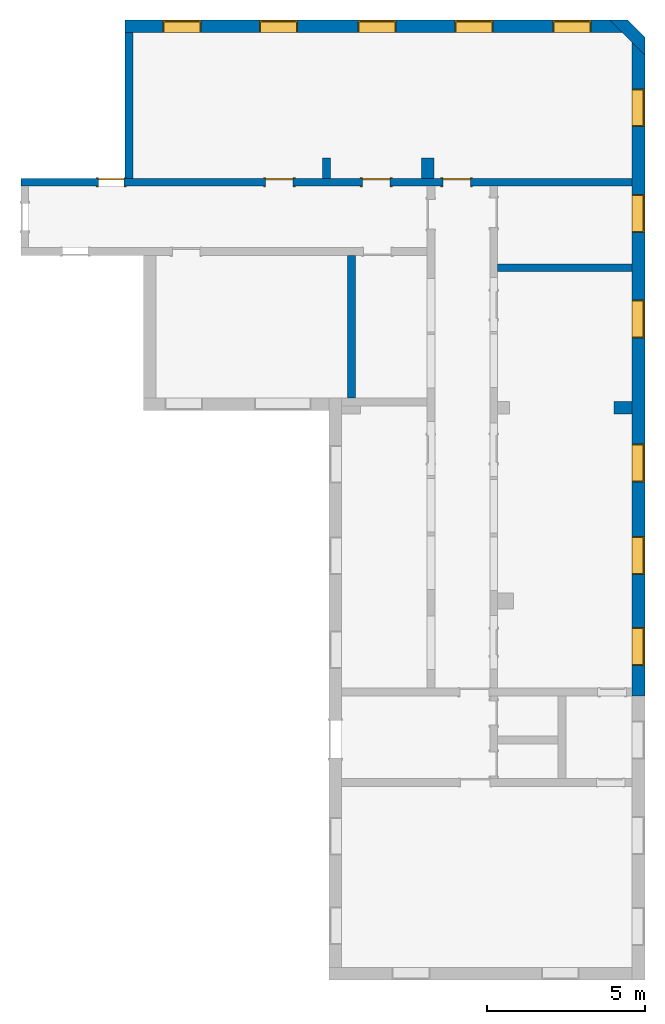
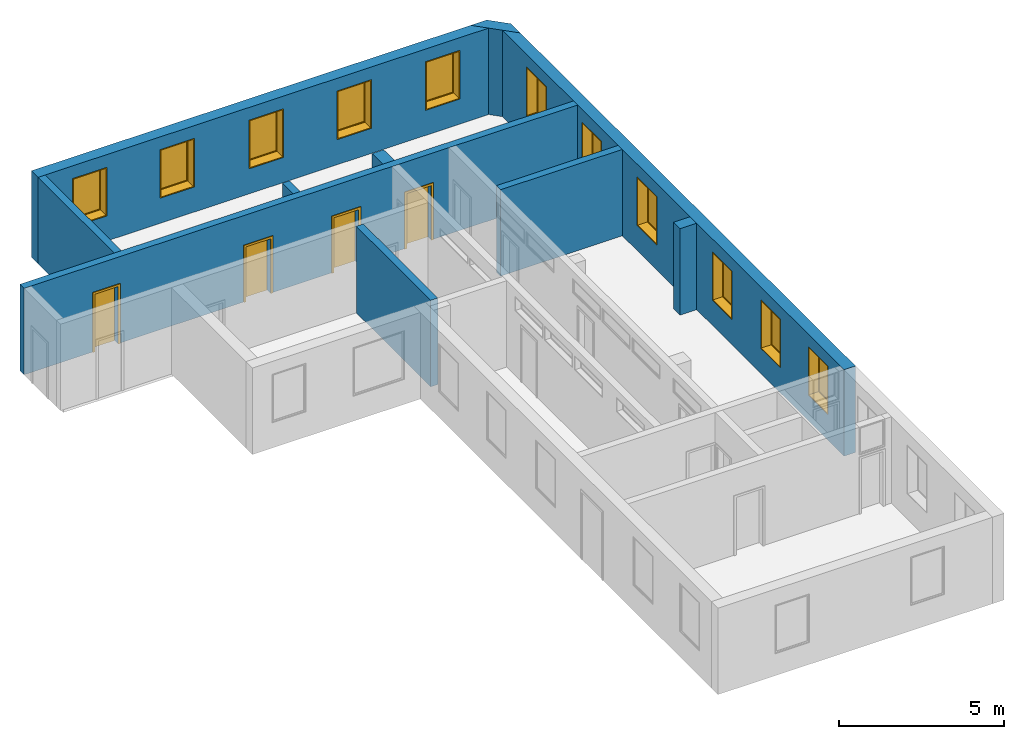
"""IFC2X3 building model written with IfcOpenShell, lengths in millimetres."""

from ifc_helpers import new_model, entity, si_unit, converted_unit, derived_unit, direction, frame, frame_2d, origin, origin_2d_with_axis, place, context, subcontext, project, spatial, polyline, rectangle, outline, extrude, source, transform, mapped, material, material_list, layer, layer_set, layer_usage, type_object, type_shapes, element, fill, save


model = new_model("IFC2X3")

# Units and contexts
model_context = context("Model", 3, precision=0.01, world=origin(), true_north=direction((6.12303176911189e-17, 1.0)))
context_of_model = context(None, 3, precision=0.01, world=origin(), true_north=direction((6.12303176911189e-17, 1.0)))
body_context = subcontext(model_context, "Body", "Model", "MODEL_VIEW")
ifc_project = project(units=[si_unit("LENGTHUNIT", "METRE", prefix="MILLI"), si_unit("AREAUNIT", "SQUARE_METRE"), si_unit("VOLUMEUNIT", "CUBIC_METRE"), converted_unit("PLANEANGLEUNIT", "DEGREE", entity("IfcRatioMeasure", 0.0174532925199433), si_unit("PLANEANGLEUNIT", "RADIAN"), dimensions=[0, 0, 0, 0, 0, 0, 0]), si_unit("MASSUNIT", "GRAM", prefix="KILO"), si_unit("TIMEUNIT", "SECOND"), si_unit("FREQUENCYUNIT", "HERTZ"), si_unit("THERMODYNAMICTEMPERATUREUNIT", "DEGREE_CELSIUS"), derived_unit("THERMALTRANSMITTANCEUNIT", [(si_unit("MASSUNIT", "GRAM", prefix="KILO"), 1), (si_unit("THERMODYNAMICTEMPERATUREUNIT", "KELVIN"), -1), (si_unit("TIMEUNIT", "SECOND"), -3)]), derived_unit("VOLUMETRICFLOWRATEUNIT", [(si_unit("LENGTHUNIT", "METRE"), 3), (si_unit("TIMEUNIT", "SECOND"), -1)]), si_unit("ELECTRICCURRENTUNIT", "AMPERE"), si_unit("ELECTRICVOLTAGEUNIT", "VOLT"), si_unit("POWERUNIT", "WATT"), si_unit("FORCEUNIT", "NEWTON", prefix="KILO"), si_unit("ILLUMINANCEUNIT", "LUX"), si_unit("LUMINOUSFLUXUNIT", "LUMEN"), si_unit("LUMINOUSINTENSITYUNIT", "CANDELA"), si_unit("PRESSUREUNIT", "PASCAL")], contexts=[model_context, context_of_model])

# Site, building, storey
site_placement = place(None, origin())
site = spatial("IfcSite", under=ifc_project, at=site_placement, CompositionType="ELEMENT")
building_placement = place(site_placement, origin())
building = spatial("IfcBuilding", under=site, at=building_placement, CompositionType="ELEMENT")
storey_1_placement = place(building_placement, origin())
storey_1 = spatial("IfcBuildingStorey", under=building, at=storey_1_placement, Name="i Plan", CompositionType="ELEMENT", Elevation=-5.41433564649196e-13)

# Wall, openings
ifc_material_1 = material(Name="Brick, Common")
ifc_layer_1 = layer(ifc_material_1, 400.0)
ifc_layer_set_1 = layer_set([ifc_layer_1], Name="Basic Wall:400mm")
ifc_layer_usage_1 = layer_usage(ifc_layer_set_1, "AXIS2", "NEGATIVE", 200.0)
wall_type_1 = type_object("IfcWallType", Name="Basic Wall:400mm", PredefinedType="STANDARD", material=ifc_layer_set_1)
wall_1_placement = place(storey_1_placement, frame((-10978.4537950618, 14416.3951971478, 0.0)))
wall_1 = element("IfcWallStandardCase", 1, at=wall_1_placement, inside=storey_1, type_object=wall_type_1, material=ifc_layer_usage_1, Name="Basic Wall:400mm", ObjectType="Basic Wall:400mm", context=body_context, shape_type="SweptSolid", body=[
    extrude(outline(polyline([(15778.1296869568, -200.0), (15378.1296869568, 200.0), (0.0, 200.0), (0.0, -200.0), (250.0, -200.0), (15778.1296869568, -200.0)])), origin(), (0.0, 0.0, 1.0), 3199.99999999984),
])
opening_1_placement = place(wall_1_placement, frame((7390.0, -200.0, 930.0)))
opening_1 = element("IfcOpeningElement", 2, at=opening_1_placement, cuts=wall_1, Name="M_Fixed:72_1", ObjectType="Opening", context=body_context, shape_type="SweptSolid", body=[
    extrude(rectangle(XDim=1800.0, YDim=1200.0, at=frame_2d((899.999999999998, 600.0), x_axis=(1.0, 0.0))), frame((0.0, 0.0, 0.0), z_axis=(0.0, 1.0, 0.0), x_axis=(0.0, 0.0, 1.0)), (0.0, 0.0, 1.0), 400.0),
])
opening_2_placement = place(wall_1_placement, frame((10470.0, -200.0, 930.0)))
opening_2 = element("IfcOpeningElement", 3, at=opening_2_placement, cuts=wall_1, Name="M_Fixed:72_1", ObjectType="Opening", context=body_context, shape_type="SweptSolid", body=[
    extrude(rectangle(XDim=1800.0, YDim=1200.0, at=frame_2d((899.999999999998, 600.0), x_axis=(1.0, 0.0))), frame((0.0, 0.0, 0.0), z_axis=(0.0, 1.0, 0.0), x_axis=(0.0, 0.0, 1.0)), (0.0, 0.0, 1.0), 400.0),
])
opening_3_placement = place(wall_1_placement, frame((13570.0, -200.0, 930.0)))
opening_3 = element("IfcOpeningElement", 4, at=opening_3_placement, cuts=wall_1, Name="M_Fixed:72_1", ObjectType="Opening", context=body_context, shape_type="SweptSolid", body=[
    extrude(rectangle(XDim=1800.0, YDim=1200.0, at=frame_2d((899.999999999998, 600.0), x_axis=(1.0, 0.0))), frame((0.0, 0.0, 0.0), z_axis=(0.0, 1.0, 0.0), x_axis=(0.0, 0.0, 1.0)), (0.0, 0.0, 1.0), 400.0),
])
opening_4_placement = place(wall_1_placement, frame((4270.0, -200.0, 930.0)))
opening_4 = element("IfcOpeningElement", 5, at=opening_4_placement, cuts=wall_1, Name="M_Fixed:72_1", ObjectType="Opening", context=body_context, shape_type="SweptSolid", body=[
    extrude(rectangle(XDim=1800.0, YDim=1200.0, at=frame_2d((899.999999999998, 600.0), x_axis=(1.0, 0.0))), frame((0.0, 0.0, 0.0), z_axis=(0.0, 1.0, 0.0), x_axis=(0.0, 0.0, 1.0)), (0.0, 0.0, 1.0), 400.0),
])
opening_5_placement = place(wall_1_placement, frame((1210.0, -200.0, 930.0)))
opening_5 = element("IfcOpeningElement", 6, at=opening_5_placement, cuts=wall_1, Name="M_Fixed:72_1", ObjectType="Opening", context=body_context, shape_type="SweptSolid", body=[
    extrude(rectangle(XDim=1800.0, YDim=1200.0, at=frame_2d((899.999999999998, 600.0), x_axis=(1.0, 0.0))), frame((0.0, 0.0, 0.0), z_axis=(0.0, 1.0, 0.0), x_axis=(0.0, 0.0, 1.0)), (0.0, 0.0, 1.0), 400.0),
])

# Storey
storey_2_placement = place(building_placement, frame((0.0, 0.0, 960.0)))
storey_2 = spatial("IfcBuildingStorey", under=building, at=storey_2_placement, Name="Bottom windows", CompositionType="ELEMENT", Elevation=959.999999999999)

# Window
ifc_material_2 = material(Name="Glass")
ifc_material_3 = material(Name="Sash")
ifc_material_list_1 = material_list([ifc_material_2, ifc_material_3])
ifc_material_list_2 = material_list([ifc_material_2, ifc_material_3])
window_style = type_object("IfcWindowStyle", Name="72", ConstructionType="NOTDEFINED", OperationType="NOTDEFINED", ParameterTakesPrecedence=False, Sizeable=False, material=ifc_material_list_2)
shared_shape_1 = source(origin(), body_context, "Body", "SweptSolid", [
    extrude(rectangle(XDim=12.0, YDim=1074.0, at=origin_2d_with_axis()), frame((600.0, 359.0, 63.0), z_axis=(0.0, 0.0, 1.0), x_axis=(0.0, -1.0, 0.0)), (0.0, 0.0, 1.0), 1674.0),
    extrude(outline(polyline([(-581.0, -881.0), (581.0, -881.0), (581.0, 881.0), (-581.0, 881.0), (-581.0, -881.0)]), holes=[polyline([(-537.0, -837.0), (-537.0, 837.0), (537.0, 837.0), (537.0, -837.0), (-537.0, -837.0)])]), frame((600.0, 337.0, 900.0), z_axis=(0.0, 1.0, 0.0), x_axis=(1.0, 0.0, 0.0)), (0.0, 0.0, 1.0), 44.0000000000274),
    extrude(outline(polyline([(-600.0, -900.0), (600.0, -900.0), (600.0, 900.0), (-600.0, 900.0), (-600.0, -900.0)]), holes=[polyline([(-581.0, -881.0), (-581.0, 881.0), (581.0, 881.0), (581.0, -881.0), (-581.0, -881.0)])]), frame((600.0, 337.0, 900.0), z_axis=(0.0, 1.0, 0.0), x_axis=(1.0, 0.0, 0.0)), (0.0, 0.0, 1.0), 63.0000000000275),
    extrude(outline(polyline([(-600.0, -900.0), (600.0, -900.0), (600.0, 900.0), (-600.0, 900.0), (-600.0, -900.0)]), holes=[polyline([(-568.0, -868.0), (-568.0, 868.0), (568.0, 868.0), (568.0, -868.0), (-568.0, -868.0)])]), frame((600.0, 0.0, 900.0), z_axis=(0.0, 1.0, 0.0), x_axis=(1.0, 0.0, 0.0)), (0.0, 0.0, 1.0), 336.999999999973),
])
type_shapes(window_style, [shared_shape_1])
window_1_placement = place(opening_1_placement, origin())
window_1 = element("IfcWindow", 7, at=window_1_placement, inside=storey_2, type_object=window_style, material=ifc_material_list_1, Name="M_Fixed:72", ObjectType="72", OverallHeight=1800.0, OverallWidth=1200.0, context=body_context, shape_type="MappedRepresentation", body=[
    mapped(shared_shape_1, transform((0.0, 0.0, 0.0), scale=1.0)),
])

fill(opening_1, window_1)

ifc_material_list_3 = material_list([ifc_material_2, ifc_material_3])
window_2_placement = place(opening_2_placement, origin())
window_2 = element("IfcWindow", 8, at=window_2_placement, inside=storey_2, type_object=window_style, material=ifc_material_list_3, Name="M_Fixed:72", ObjectType="72", OverallHeight=1800.0, OverallWidth=1200.0, context=body_context, shape_type="MappedRepresentation", body=[
    mapped(shared_shape_1, transform((0.0, 0.0, 0.0), scale=1.0)),
])

fill(opening_2, window_2)

ifc_material_list_4 = material_list([ifc_material_2, ifc_material_3])
window_3_placement = place(opening_3_placement, origin())
window_3 = element("IfcWindow", 9, at=window_3_placement, inside=storey_2, type_object=window_style, material=ifc_material_list_4, Name="M_Fixed:72", ObjectType="72", OverallHeight=1800.0, OverallWidth=1200.0, context=body_context, shape_type="MappedRepresentation", body=[
    mapped(shared_shape_1, transform((0.0, 0.0, 0.0), scale=1.0)),
])

fill(opening_3, window_3)

ifc_material_list_5 = material_list([ifc_material_2, ifc_material_3])
window_4_placement = place(opening_4_placement, origin())
window_4 = element("IfcWindow", 10, at=window_4_placement, inside=storey_2, type_object=window_style, material=ifc_material_list_5, Name="M_Fixed:72", ObjectType="72", OverallHeight=1800.0, OverallWidth=1200.0, context=body_context, shape_type="MappedRepresentation", body=[
    mapped(shared_shape_1, transform((0.0, 0.0, 0.0), scale=1.0)),
])

fill(opening_4, window_4)

ifc_material_list_6 = material_list([ifc_material_2, ifc_material_3])
window_5_placement = place(opening_5_placement, origin())
window_5 = element("IfcWindow", 11, at=window_5_placement, inside=storey_2, type_object=window_style, material=ifc_material_list_6, Name="M_Fixed:72", ObjectType="72", OverallHeight=1800.0, OverallWidth=1200.0, context=body_context, shape_type="MappedRepresentation", body=[
    mapped(shared_shape_1, transform((0.0, 0.0, 0.0), scale=1.0)),
])

fill(opening_5, window_5)

# Wall
ifc_layer_usage_2 = layer_usage(ifc_layer_set_1, "AXIS2", "NEGATIVE", 200.0)
wall_2_placement = place(storey_1_placement, frame((4541.09724813232, 14757.8165533851, 0.0), z_axis=(0.0, 0.0, 1.0), x_axis=(0.707106781186546, -0.707106781186549, 0.0)))
element("IfcWallStandardCase", 12, at=wall_2_placement, inside=storey_1, type_object=wall_type_1, material=ifc_layer_usage_2, Name="Basic Wall:400mm", ObjectType="Basic Wall:400mm", context=body_context, shape_type="SweptSolid", body=[
    extrude(outline(polyline([(1558.97832483456, -200.0), (1158.97832483456, 200.0), (400.0, 200.0), (0.0, -200.0), (565.685424949238, -200.0), (993.292899885323, -200.0), (1558.97832483456, -200.0)])), origin(), (0.0, 0.0, 1.0), 3199.99999999984),
])

# Wall, openings, windows
ifc_layer_usage_3 = layer_usage(ifc_layer_set_1, "AXIS2", "NEGATIVE", 200.0)
wall_3_placement = place(storey_1_placement, frame((5302.04003710837, 13914.0310519344, 0.0), z_axis=(0.0, 0.0, 1.0), x_axis=(0.0, -1.0, 0.0)))
wall_3 = element("IfcWallStandardCase", 13, at=wall_3_placement, inside=storey_1, type_object=wall_type_1, material=ifc_layer_usage_3, Name="Basic Wall:400mm", ObjectType="Basic Wall:400mm", context=body_context, shape_type="SweptSolid", body=[
    extrude(outline(polyline([(20727.1273479506, -200.0), (20727.1273479506, 200.0), (400.0, 200.0), (0.0, -200.0), (4317.22230867366, -200.0), (4567.22230867366, -200.0), (7027.22230867366, -200.0), (7277.22230867366, -200.0), (11383.6923277793, -200.0), (11783.6923277793, -200.0), (20477.1273479506, -200.0), (20727.1273479506, -200.0)])), origin(), (0.0, 0.0, 1.0), 3199.99999999984),
])
opening_6_placement = place(wall_3_placement, frame((12737.2223086737, -200.0, 930.0)))
opening_6 = element("IfcOpeningElement", 14, at=opening_6_placement, cuts=wall_3, Name="M_Fixed:72_1", ObjectType="Opening", context=body_context, shape_type="SweptSolid", body=[
    extrude(rectangle(XDim=1800.0, YDim=1200.0, at=frame_2d((899.999999999998, 600.0), x_axis=(1.0, 0.0))), frame((0.0, 0.0, 0.0), z_axis=(0.0, 1.0, 0.0), x_axis=(0.0, 0.0, 1.0)), (0.0, 0.0, 1.0), 400.0),
])
opening_7_placement = place(wall_3_placement, frame((1477.22230867366, -200.0, 930.0)))
opening_7 = element("IfcOpeningElement", 15, at=opening_7_placement, cuts=wall_3, Name="M_Fixed:72_1", ObjectType="Opening", context=body_context, shape_type="SweptSolid", body=[
    extrude(rectangle(XDim=1800.0, YDim=1200.0, at=frame_2d((899.999999999998, 600.0), x_axis=(1.0, 0.0))), frame((0.0, 0.0, 0.0), z_axis=(0.0, 1.0, 0.0), x_axis=(0.0, 0.0, 1.0)), (0.0, 0.0, 1.0), 400.0),
])
opening_8_placement = place(wall_3_placement, frame((4827.22230867366, -200.0, 930.0)))
opening_8 = element("IfcOpeningElement", 16, at=opening_8_placement, cuts=wall_3, Name="M_Fixed:72_1", ObjectType="Opening", context=body_context, shape_type="SweptSolid", body=[
    extrude(rectangle(XDim=1800.0, YDim=1200.0, at=frame_2d((899.999999999998, 600.0), x_axis=(1.0, 0.0))), frame((0.0, 0.0, 0.0), z_axis=(0.0, 1.0, 0.0), x_axis=(0.0, 0.0, 1.0)), (0.0, 0.0, 1.0), 400.0),
])
opening_9_placement = place(wall_3_placement, frame((8177.22230867366, -200.0, 930.0)))
opening_9 = element("IfcOpeningElement", 17, at=opening_9_placement, cuts=wall_3, Name="M_Fixed:72_1", ObjectType="Opening", context=body_context, shape_type="SweptSolid", body=[
    extrude(rectangle(XDim=1800.0, YDim=1200.0, at=frame_2d((899.999999999998, 599.999999999999), x_axis=(1.0, 0.0))), frame((0.0, 0.0, 0.0), z_axis=(0.0, 1.0, 0.0), x_axis=(0.0, 0.0, 1.0)), (0.0, 0.0, 1.0), 400.0),
])
opening_10_placement = place(wall_3_placement, frame((15677.1273479506, -200.0, 930.0)))
opening_10 = element("IfcOpeningElement", 18, at=opening_10_placement, cuts=wall_3, Name="M_Fixed:72_1", ObjectType="Opening", context=body_context, shape_type="SweptSolid", body=[
    extrude(rectangle(XDim=1800.0, YDim=1200.0, at=frame_2d((899.999999999998, 600.0), x_axis=(1.0, 0.0))), frame((0.0, 0.0, 0.0), z_axis=(0.0, 1.0, 0.0), x_axis=(0.0, 0.0, 1.0)), (0.0, 0.0, 1.0), 400.0),
])
opening_11_placement = place(wall_3_placement, frame((18557.1273479506, -200.0, 946.352774904419)))
opening_11 = element("IfcOpeningElement", 19, at=opening_11_placement, cuts=wall_3, Name="M_Fixed:72_1", ObjectType="Opening", context=body_context, shape_type="SweptSolid", body=[
    extrude(rectangle(XDim=1800.0, YDim=1200.0, at=frame_2d((899.999999999998, 600.0), x_axis=(1.0, 0.0))), frame((0.0, 0.0, 0.0), z_axis=(0.0, 1.0, 0.0), x_axis=(0.0, 0.0, 1.0)), (0.0, 0.0, 1.0), 400.0),
])
ifc_material_list_7 = material_list([ifc_material_2, ifc_material_3])
window_6_placement = place(opening_7_placement, origin())
window_6 = element("IfcWindow", 20, at=window_6_placement, inside=storey_2, type_object=window_style, material=ifc_material_list_7, Name="M_Fixed:72", ObjectType="72", OverallHeight=1800.0, OverallWidth=1200.0, context=body_context, shape_type="MappedRepresentation", body=[
    mapped(shared_shape_1, transform((0.0, 0.0, 0.0), scale=1.0)),
])
fill(opening_7, window_6)
ifc_material_list_8 = material_list([ifc_material_2, ifc_material_3])
window_7_placement = place(opening_8_placement, origin())
window_7 = element("IfcWindow", 21, at=window_7_placement, inside=storey_2, type_object=window_style, material=ifc_material_list_8, Name="M_Fixed:72", ObjectType="72", OverallHeight=1800.0, OverallWidth=1200.0, context=body_context, shape_type="MappedRepresentation", body=[
    mapped(shared_shape_1, transform((0.0, 0.0, 0.0), scale=1.0)),
])
fill(opening_8, window_7)
ifc_material_list_9 = material_list([ifc_material_2, ifc_material_3])
window_8_placement = place(opening_9_placement, origin())
window_8 = element("IfcWindow", 22, at=window_8_placement, inside=storey_2, type_object=window_style, material=ifc_material_list_9, Name="M_Fixed:72", ObjectType="72", OverallHeight=1800.0, OverallWidth=1200.0, context=body_context, shape_type="MappedRepresentation", body=[
    mapped(shared_shape_1, transform((0.0, 0.0, 0.0), scale=1.0)),
])
fill(opening_9, window_8)
ifc_material_list_10 = material_list([ifc_material_2, ifc_material_3])
window_9_placement = place(opening_6_placement, origin())
window_9 = element("IfcWindow", 23, at=window_9_placement, inside=storey_2, type_object=window_style, material=ifc_material_list_10, Name="M_Fixed:72", ObjectType="72", OverallHeight=1800.0, OverallWidth=1200.0, context=body_context, shape_type="MappedRepresentation", body=[
    mapped(shared_shape_1, transform((0.0, 0.0, 0.0), scale=1.0)),
])
fill(opening_6, window_9)
ifc_material_list_11 = material_list([ifc_material_2, ifc_material_3])
window_10_placement = place(opening_10_placement, origin())
window_10 = element("IfcWindow", 24, at=window_10_placement, inside=storey_2, type_object=window_style, material=ifc_material_list_11, Name="M_Fixed:72", ObjectType="72", OverallHeight=1800.0, OverallWidth=1200.0, context=body_context, shape_type="MappedRepresentation", body=[
    mapped(shared_shape_1, transform((0.0, 0.0, 0.0), scale=1.0)),
])
fill(opening_10, window_10)
ifc_material_list_12 = material_list([ifc_material_2, ifc_material_3])
window_11_placement = place(opening_11_placement, origin())
window_11 = element("IfcWindow", 25, at=window_11_placement, inside=storey_1, type_object=window_style, material=ifc_material_list_12, Name="M_Fixed:72", ObjectType="72", OverallHeight=1800.0, OverallWidth=1200.0, context=body_context, shape_type="MappedRepresentation", body=[
    mapped(shared_shape_1, transform((0.0, 0.0, 0.0), scale=1.0)),
])
fill(opening_11, window_11)

# Wall, openings, doors
ifc_material_4 = material(Name="Default Wall")
ifc_layer_2 = layer(ifc_material_4, 250.0)
ifc_layer_set_2 = layer_set([ifc_layer_2], Name="Basic Wall:250 mm")
ifc_layer_usage_4 = layer_usage(ifc_layer_set_2, "AXIS2", "NEGATIVE", 125.0)
wall_type_2 = type_object("IfcWallType", Name="Basic Wall:250 mm", PredefinedType="STANDARD", material=ifc_layer_set_2)
wall_4_placement = place(storey_1_placement, frame((-14277.9599628916, 9471.8087432608, 0.0)))
wall_4 = element("IfcWallStandardCase", 26, at=wall_4_placement, inside=storey_1, type_object=wall_type_2, material=ifc_layer_usage_4, Name="Basic Wall:250 mm", ObjectType="Basic Wall:250 mm", context=body_context, shape_type="SweptSolid", body=[
    extrude(rectangle(XDim=19380.0, YDim=249.999999999999, at=frame_2d((9690.0, 5.6843418860808e-14), x_axis=(-1.0, 0.0))), origin(), (0.0, 0.0, 1.0), 3199.99999999984),
])
opening_12_placement = place(wall_4_placement, frame((13386.3718701131, -125.0, 0.0)))
opening_12 = element("IfcOpeningElement", 27, at=opening_12_placement, cuts=wall_4, Name="M_Single-Flush:0864 x 2032mm:1", ObjectType="Opening", context=body_context, shape_type="SweptSolid", body=[
    extrude(rectangle(XDim=863.999999999999, YDim=2032.0, at=frame_2d((1016.0, 432.0), x_axis=(0.0, 1.0))), frame((0.0, 0.0, 0.0), z_axis=(0.0, 1.0, 0.0), x_axis=(0.0, 0.0, 1.0)), (0.0, 0.0, 1.0), 250.0),
])
opening_13_placement = place(wall_4_placement, frame((10836.3718701131, -125.0, 0.0)))
opening_13 = element("IfcOpeningElement", 28, at=opening_13_placement, cuts=wall_4, Name="M_Single-Flush:0864 x 2032mm:1", ObjectType="Opening", context=body_context, shape_type="SweptSolid", body=[
    extrude(rectangle(XDim=863.999999999999, YDim=2032.0, at=frame_2d((1016.0, 432.0), x_axis=(0.0, 1.0))), frame((0.0, 0.0, 0.0), z_axis=(0.0, 1.0, 0.0), x_axis=(0.0, 0.0, 1.0)), (0.0, 0.0, 1.0), 250.0),
])
opening_14_placement = place(wall_4_placement, frame((7762.37187011309, -125.0, 0.0)))
opening_14 = element("IfcOpeningElement", 29, at=opening_14_placement, cuts=wall_4, Name="M_Single-Flush:0864 x 2032mm:1", ObjectType="Opening", context=body_context, shape_type="SweptSolid", body=[
    extrude(rectangle(XDim=863.999999999999, YDim=2032.0, at=frame_2d((1016.0, 432.0), x_axis=(0.0, -1.0))), frame((0.0, 0.0, 0.0), z_axis=(0.0, 1.0, 0.0), x_axis=(0.0, 0.0, 1.0)), (0.0, 0.0, 1.0), 250.0),
])
opening_15_placement = place(wall_4_placement, frame((2466.50616782982, -125.0, 0.0)))
opening_15 = element("IfcOpeningElement", 30, at=opening_15_placement, cuts=wall_4, Name="M_Single-Flush:0813 x 2134mm:1", ObjectType="Opening", context=body_context, shape_type="SweptSolid", body=[
    extrude(rectangle(XDim=813.0, YDim=2134.0, at=frame_2d((1067.0, 406.5), x_axis=(0.0, 1.0))), frame((0.0, 0.0, 0.0), z_axis=(0.0, 1.0, 0.0), x_axis=(0.0, 0.0, 1.0)), (0.0, 0.0, 1.0), 250.0),
])
ifc_material_5 = material(Name="Door - Frame")
ifc_material_6 = material(Name="Door - Panel")
ifc_material_list_13 = material_list([ifc_material_5, ifc_material_6])
ifc_material_list_14 = material_list([ifc_material_5, ifc_material_6])
door_style_1 = type_object("IfcDoorStyle", Name="0813 x 2134mm", ConstructionType="NOTDEFINED", OperationType="SINGLE_SWING_RIGHT", ParameterTakesPrecedence=False, Sizeable=False, material=ifc_material_list_14)
shared_shape_2 = source(origin(), body_context, "Body", "SweptSolid", [
    extrude(outline(polyline([(-482.5, -1124.0), (482.5, -1124.0), (482.5, 1086.0), (406.5, 1086.0), (406.5, -1048.0), (-406.5, -1048.0), (-406.5, 1086.0), (-482.5, 1086.0), (-482.5, -1124.0)])), frame((406.500000000001, 250.0, 1086.0), z_axis=(0.0, 1.0, 0.0), x_axis=(1.0, 0.0, 0.0)), (0.0, 0.0, 1.0), 24.9999999999945),
    extrude(outline(polyline([(-1124.0, -482.499999999997), (1086.0, -482.499999999997), (1086.0, -406.500000000007), (-1048.0, -406.500000000007), (-1048.0, 406.500000000002), (1086.0, 406.500000000002), (1086.0, 482.500000000003), (-1124.0, 482.500000000003), (-1124.0, -482.499999999997)])), frame((406.500000000003, -25.0, 1086.0), z_axis=(0.0, 1.0, 0.0), x_axis=(0.0, 0.0, -1.0)), (0.0, 0.0, 1.0), 25.0000000000056),
    extrude(rectangle(XDim=51.0, YDim=813.0, at=frame_2d((5.32907051820075e-15, 0.0), x_axis=(1.0, 0.0))), frame((406.5, 224.499999999999, 0.0), z_axis=(0.0, 0.0, 1.0), x_axis=(0.0, 1.0, 0.0)), (0.0, 0.0, 1.0), 2134.0),
])
type_shapes(door_style_1, [shared_shape_2])
door_1_placement = place(opening_15_placement, origin())
door_1 = element("IfcDoor", 31, at=door_1_placement, inside=storey_1, type_object=door_style_1, material=ifc_material_list_13, Name="M_Single-Flush:0813 x 2134mm", ObjectType="0813 x 2134mm", OverallHeight=2134.0, OverallWidth=812.999999999999, context=body_context, shape_type="MappedRepresentation", body=[
    mapped(shared_shape_2, transform((0.0, 0.0, 0.0), scale=1.0)),
])
fill(opening_15, door_1)
ifc_material_list_15 = material_list([ifc_material_5, ifc_material_6])
ifc_material_list_16 = material_list([ifc_material_5, ifc_material_6])
door_style_2 = type_object("IfcDoorStyle", Name="0864 x 2032mm", ConstructionType="NOTDEFINED", OperationType="SINGLE_SWING_RIGHT", ParameterTakesPrecedence=False, Sizeable=False, material=ifc_material_list_16)
shared_shape_3 = source(origin(), body_context, "Body", "SweptSolid", [
    extrude(outline(polyline([(-508.0, -1073.0), (508.0, -1073.0), (508.0, 1035.0), (432.0, 1035.0), (432.0, -997.0), (-432.0, -997.0), (-432.0, 1035.0), (-508.0, 1035.0), (-508.0, -1073.0)])), frame((432.0, 250.0, 1035.0), z_axis=(0.0, 1.0, 0.0), x_axis=(1.0, 0.0, 0.0)), (0.0, 0.0, 1.0), 24.9999999999945),
    extrude(outline(polyline([(-1073.0, -508.0), (1035.0, -508.0), (1035.0, -432.0), (-997.0, -432.0), (-997.0, 432.0), (1035.0, 432.0), (1035.0, 508.0), (-1073.0, 508.0), (-1073.0, -508.0)])), frame((432.0, -25.0, 1035.0), z_axis=(0.0, 1.0, 0.0), x_axis=(0.0, 0.0, -1.0)), (0.0, 0.0, 1.0), 25.0000000000056),
    extrude(rectangle(XDim=51.0, YDim=864.0, at=frame_2d((5.32907051820075e-15, 0.0), x_axis=(1.0, 0.0))), frame((432.0, 224.499999999999, 0.0), z_axis=(0.0, 0.0, 1.0), x_axis=(0.0, 1.0, 0.0)), (0.0, 0.0, 1.0), 2032.0),
])
type_shapes(door_style_2, [shared_shape_3])
door_2_placement = place(opening_12_placement, origin())
door_2 = element("IfcDoor", 32, at=door_2_placement, inside=storey_1, type_object=door_style_2, material=ifc_material_list_15, Name="M_Single-Flush:0864 x 2032mm", ObjectType="0864 x 2032mm", OverallHeight=2032.0, OverallWidth=864.0, context=body_context, shape_type="MappedRepresentation", body=[
    mapped(shared_shape_3, transform((0.0, 0.0, 0.0), scale=1.0)),
])
fill(opening_12, door_2)
ifc_material_list_17 = material_list([ifc_material_5, ifc_material_6])
door_3_placement = place(opening_13_placement, origin())
door_3 = element("IfcDoor", 33, at=door_3_placement, inside=storey_1, type_object=door_style_2, material=ifc_material_list_17, Name="M_Single-Flush:0864 x 2032mm", ObjectType="0864 x 2032mm", OverallHeight=2032.0, OverallWidth=864.0, context=body_context, shape_type="MappedRepresentation", body=[
    mapped(shared_shape_3, transform((0.0, 0.0, 0.0), scale=1.0)),
])
fill(opening_13, door_3)
ifc_material_list_18 = material_list([ifc_material_5, ifc_material_6])
ifc_material_list_19 = material_list([ifc_material_5, ifc_material_6])
door_style_3 = type_object("IfcDoorStyle", Name="0864 x 2032mm", ConstructionType="NOTDEFINED", OperationType="SINGLE_SWING_LEFT", ParameterTakesPrecedence=False, Sizeable=False, material=ifc_material_list_19)
shared_shape_4 = source(origin(), body_context, "Body", "SweptSolid", [
    extrude(outline(polyline([(-508.0, -1073.0), (508.0, -1073.0), (508.0, 1035.0), (432.0, 1035.0), (432.0, -997.0), (-432.0, -997.0), (-432.0, 1035.0), (-508.0, 1035.0), (-508.0, -1073.0)])), frame((432.0, 275.0, 1035.0), z_axis=(0.0, -1.0, 0.0), x_axis=(-1.0, 0.0, 0.0)), (0.0, 0.0, 1.0), 24.9999999999945),
    extrude(outline(polyline([(-1073.0, -508.0), (1035.0, -508.0), (1035.0, -432.0), (-997.0, -432.0), (-997.0, 432.0), (1035.0, 432.0), (1035.0, 508.0), (-1073.0, 508.0), (-1073.0, -508.0)])), frame((432.0, 0.0, 1035.0), z_axis=(0.0, -1.0, 0.0), x_axis=(0.0, 0.0, -1.0)), (0.0, 0.0, 1.0), 25.0000000000056),
    extrude(rectangle(XDim=864.0, YDim=51.0, at=frame_2d((0.0, 5.32907051820075e-15), x_axis=(1.0, 0.0))), frame((432.0, 224.499999999994, 0.0)), (0.0, 0.0, 1.0), 2032.0),
])
type_shapes(door_style_3, [shared_shape_4])
door_4_placement = place(opening_14_placement, origin())
door_4 = element("IfcDoor", 34, at=door_4_placement, inside=storey_1, type_object=door_style_3, material=ifc_material_list_18, Name="M_Single-Flush:0864 x 2032mm", ObjectType="0864 x 2032mm", OverallHeight=2032.0, OverallWidth=864.0, context=body_context, shape_type="MappedRepresentation", body=[
    mapped(shared_shape_4, transform((0.0, 0.0, 0.0), scale=1.0)),
])
fill(opening_14, door_4)

# Walls
ifc_layer_usage_5 = layer_usage(ifc_layer_set_2, "AXIS2", "NEGATIVE", 125.0)
wall_5_placement = place(storey_1_placement, frame((-10853.4537950618, 9596.80874326078, 0.0), z_axis=(0.0, 0.0, 1.0), x_axis=(0.0, 1.0, 0.0)))
element("IfcWallStandardCase", 35, at=wall_5_placement, inside=storey_1, type_object=wall_type_2, material=ifc_layer_usage_5, Name="Basic Wall:250 mm", ObjectType="Basic Wall:250 mm", context=body_context, shape_type="SweptSolid", body=[
    extrude(rectangle(XDim=4619.58645388702, YDim=249.999999999999, at=frame_2d((2309.79322694351, -4.2632564145606e-14), x_axis=(-1.0, 0.0))), origin(), (0.0, 0.0, 1.0), 3199.99999999984),
])
ifc_layer_usage_6 = layer_usage(ifc_layer_set_2, "AXIS2", "NEGATIVE", 125.0)
wall_6_placement = place(storey_1_placement, frame((838.411907221456, 6761.80874326075, 0.0)))
element("IfcWallStandardCase", 36, at=wall_6_placement, inside=storey_1, type_object=wall_type_2, material=ifc_layer_usage_6, Name="Basic Wall:250 mm", ObjectType="Basic Wall:250 mm", context=body_context, shape_type="SweptSolid", body=[
    extrude(rectangle(XDim=4263.6281298869, YDim=249.999999999999, at=frame_2d((2131.81406494345, 0.0), x_axis=(-1.0, 0.0))), origin(), (0.0, 0.0, 1.0), 3199.99999999984),
])
ifc_layer_usage_7 = layer_usage(ifc_layer_set_2, "AXIS2", "NEGATIVE", 125.0)
wall_7_placement = place(storey_1_placement, frame((-3793.22479520071, 7147.63557153558, 0.0), z_axis=(0.0, 0.0, 1.0), x_axis=(0.0, -1.0, 0.0)))
element("IfcWallStandardCase", 37, at=wall_7_placement, inside=storey_1, type_object=wall_type_2, material=ifc_layer_usage_7, Name="Basic Wall:250 mm", ObjectType="Basic Wall:250 mm", context=body_context, shape_type="SweptSolid", body=[
    extrude(rectangle(XDim=4514.61973649557, YDim=249.999999999999, at=frame_2d((2257.30986824779, 0.0), x_axis=(-1.0, 0.0))), origin(), (0.0, 0.0, 1.0), 3199.99999999984),
])
ifc_layer_usage_8 = layer_usage(ifc_layer_set_2, "AXIS2", "NEGATIVE", 125.0)
wall_8_placement = place(storey_1_placement, frame((-4586.58809277854, 9596.80874326077, 0.0), z_axis=(0.0, 0.0, 1.0), x_axis=(0.0, 1.0, 0.0)))
element("IfcWallStandardCase", 38, at=wall_8_placement, inside=storey_1, type_object=wall_type_2, material=ifc_layer_usage_8, Name="Basic Wall:250 mm", ObjectType="Basic Wall:250 mm", context=body_context, shape_type="SweptSolid", body=[
    extrude(rectangle(XDim=649.00097548125, YDim=249.999999999999, at=frame_2d((324.500487740625, 0.0), x_axis=(-1.0, 0.0))), origin(), (0.0, 0.0, 1.0), 3199.99999999984),
])
ifc_layer_3 = layer(ifc_material_4, 400.0)
ifc_layer_set_3 = layer_set([ifc_layer_3], Name="Basic Wall:400mm 2")
ifc_layer_usage_9 = layer_usage(ifc_layer_set_3, "AXIS2", "NEGATIVE", 200.0)
wall_type_3 = type_object("IfcWallType", Name="Basic Wall:400mm 2", PredefinedType="STANDARD", material=ifc_layer_set_3)
wall_9_placement = place(storey_1_placement, frame((-1371.58809277854, 9596.80874326076, 0.0), z_axis=(0.0, 0.0, 1.0), x_axis=(0.0, 1.0, 0.0)))
element("IfcWallStandardCase", 39, at=wall_9_placement, inside=storey_1, type_object=wall_type_3, material=ifc_layer_usage_9, Name="Basic Wall:400mm 2", ObjectType="Basic Wall:400mm 2", context=body_context, shape_type="SweptSolid", body=[
    extrude(rectangle(XDim=649.000975481261, YDim=400.0, at=frame_2d((324.50048774063, 0.0), x_axis=(-1.0, 0.0))), origin(), (0.0, 0.0, 1.0), 3199.99999999984),
])
ifc_layer_usage_10 = layer_usage(ifc_layer_set_3, "AXIS2", "NEGATIVE", 200.0)
wall_10_placement = place(storey_1_placement, frame((5102.04003710835, 2330.33872415506, 0.0), z_axis=(0.0, 0.0, 1.0), x_axis=(-1.0, 0.0, 0.0)))
element("IfcWallStandardCase", 40, at=wall_10_placement, inside=storey_1, type_object=wall_type_3, material=ifc_layer_usage_10, Name="Basic Wall:400mm 2", ObjectType="Basic Wall:400mm 2", context=body_context, shape_type="SweptSolid", body=[
    extrude(rectangle(XDim=580.000000000004, YDim=400.0, at=frame_2d((290.000000000002, 0.0), x_axis=(-1.0, 0.0))), origin(), (0.0, 0.0, 1.0), 3199.99999999984),
])

save(model, "model.ifc")
